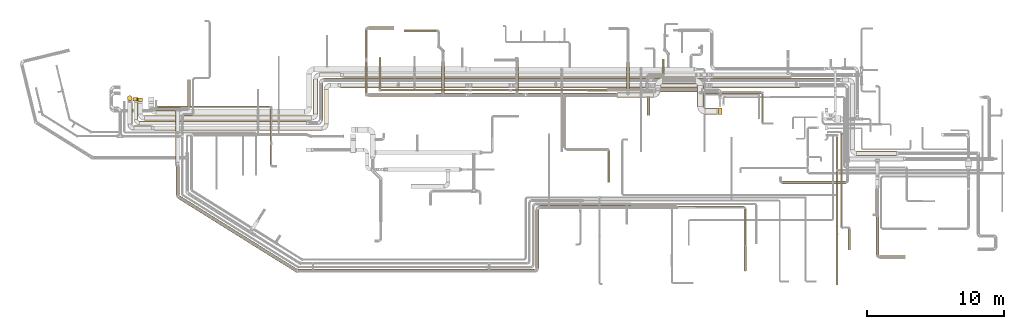
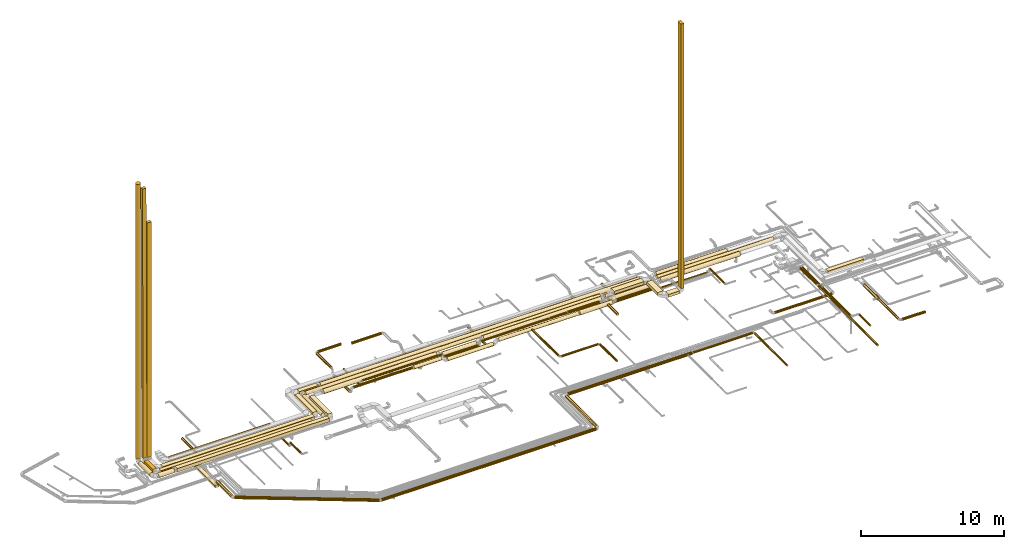
# One storey, part 1 of 92: 76 coverings.
"""IFC2X3 building model written with IfcOpenShell, lengths in millimetres."""

import ifcopenshell
import ifcopenshell.guid

model = None  # the IFC model being written
_history = None  # IfcOwnerHistory: only IFC2X3 demands one
_inside = {}  # id of a spatial element -> (the spatial element, [elements in it])
_under = {}  # id of a project, library or spatial element -> (it, [spatial elements below it])
_declared = {}  # id of a project -> (the project, [libraries it declares])
_typed = {}  # id of a type object -> (the type object, [elements of that type])
_made_of = {}  # id of a material, layer set ... -> (it, [elements and type objects made of it])


def new_model(schema):
    """Start an empty IFC model of exactly this schema.

    Asked for "IFC4X3", IfcOpenShell would pick the latest addendum, in which some entities
    have other attributes; the version numbers below select the first issue.
    IFC2X3 requires an IfcOwnerHistory on every rooted entity: one is made here for all.
    """
    global model, _history
    if schema == "IFC4X3":
        model = ifcopenshell.file(schema_version=(4, 3, 0, 0))
    else:
        model = ifcopenshell.file(schema=schema)
    _inside.clear()
    _under.clear()
    _declared.clear()
    _typed.clear()
    _made_of.clear()
    _history = None
    if model.schema == "IFC2X3":
        org = make("IfcOrganization", Name="unknown")
        user = make(
            "IfcPersonAndOrganization",
            ThePerson=make("IfcPerson", FamilyName="unknown"),
            TheOrganization=org,
        )
        app = make(
            "IfcApplication",
            ApplicationDeveloper=org,
            Version="unknown",
            ApplicationFullName="unknown",
            ApplicationIdentifier="unknown",
        )
        _history = make(
            "IfcOwnerHistory",
            OwningUser=user,
            OwningApplication=app,
            ChangeAction="ADDED",
            CreationDate=0,
        )
    return model


def make(cls, **values):
    """One entity of the class cls with the attributes given. An attribute that is None is left unset."""
    return model.create_entity(
        cls, **{name: value for name, value in values.items() if value is not None}
    )


def entity(cls, *values):
    """Any entity or typed value of the class cls, its attributes in the order of the schema. None: left unset."""
    e = model.create_entity(cls)
    for i, value in enumerate(values):
        if value is not None:
            e[i] = value
    return e


def rooted(cls, **values):
    """An entity with a GlobalId (a new one), such as an element, a storey or a relation."""
    return make(cls, GlobalId=ifcopenshell.guid.new(), OwnerHistory=_history, **values)


def si_unit(unit_type, name, prefix=None):
    """IfcSIUnit, for example si_unit("LENGTHUNIT", "METRE", prefix="MILLI")."""
    return make("IfcSIUnit", UnitType=unit_type, Prefix=prefix, Name=name)


def converted_unit(unit_type, name, factor, base, dimensions=None, offset=None):
    """IfcConversionBasedUnit, such as the inch: factor (a typed value) times the base unit."""
    return make(
        "IfcConversionBasedUnit"
        if offset is None
        else "IfcConversionBasedUnitWithOffset",
        ConversionOffset=offset,
        Dimensions=None
        if dimensions is None
        else entity("IfcDimensionalExponents", *dimensions),
        UnitType=unit_type,
        Name=name,
        ConversionFactor=make(
            "IfcMeasureWithUnit", ValueComponent=factor, UnitComponent=base
        ),
    )


def derived_unit(unit_type, elements):
    """IfcDerivedUnit: a product of units, each with its exponent."""
    return make(
        "IfcDerivedUnit",
        Elements=[
            make("IfcDerivedUnitElement", Unit=unit, Exponent=power)
            for unit, power in elements
        ],
        UnitType=unit_type,
    )


def assignment(units):
    """IfcUnitAssignment: the units of a project."""
    return None if units is None else make("IfcUnitAssignment", Units=units)


def point(xyz):
    """IfcCartesianPoint."""
    return None if xyz is None else make("IfcCartesianPoint", Coordinates=xyz)


def direction(xyz):
    """IfcDirection."""
    return None if xyz is None else make("IfcDirection", DirectionRatios=xyz)


def frame(location, z_axis=None, x_axis=None):
    """IfcAxis2Placement3D, a coordinate frame: its origin and axes. An axis left out is left unset."""
    return make(
        "IfcAxis2Placement3D",
        Location=point(location),
        Axis=direction(z_axis),
        RefDirection=direction(x_axis),
    )


def frame_2d(location, x_axis=None):
    """IfcAxis2Placement2D, a coordinate frame in the plane: its origin and x axis."""
    return make(
        "IfcAxis2Placement2D", Location=point(location), RefDirection=direction(x_axis)
    )


def origin():
    """The frame at (0, 0, 0) with its axes left unset."""
    return frame((0.0, 0.0, 0.0))


def origin_2d_with_axis():
    """The frame at (0, 0) in the plane with the x axis (1, 0) written out."""
    return frame_2d((0.0, 0.0), x_axis=(1.0, 0.0))


def place(relative_to, where):
    """IfcLocalPlacement: puts the frame where relative to a parent placement (None: the world)."""
    return make(
        "IfcLocalPlacement", PlacementRelTo=relative_to, RelativePlacement=where
    )


def context(
    kind, dimensions, precision=None, world=None, true_north=None, identifier=None
):
    """IfcGeometricRepresentationContext, for example the 3D "Model" context."""
    return make(
        "IfcGeometricRepresentationContext",
        ContextIdentifier=identifier,
        ContextType=kind,
        CoordinateSpaceDimension=dimensions,
        Precision=precision,
        WorldCoordinateSystem=world,
        TrueNorth=true_north,
    )


def subcontext(parent, identifier, kind, view, scale=None):
    """IfcGeometricRepresentationSubContext, for example "Body" below "Model"."""
    return make(
        "IfcGeometricRepresentationSubContext",
        ContextIdentifier=identifier,
        ContextType=kind,
        ParentContext=parent,
        TargetScale=scale,
        TargetView=view,
    )


def project(units=None, contexts=None):
    """IfcProject with its units and contexts."""
    return rooted(
        "IfcProject",
        Name="project",
        RepresentationContexts=contexts,
        UnitsInContext=assignment(units),
    )


def spatial(cls, under=None, at=None, **own):
    """A site, building, storey or space (cls), placed at a placement, below another one or the project."""
    s = rooted(cls, ObjectPlacement=at, **own)
    if under is not None:
        _under.setdefault(under.id(), (under, []))[1].append(s)
    return s


def profile(cls, at=None, kind="AREA", **sizes):
    """A parametric profile (cls). Its sizes go by their IFC names, for example OverallWidth=200.0."""
    return make(cls, ProfileType=kind, Position=at, **sizes)


def rectangle(**sizes):
    """IfcRectangleProfileDef."""
    return profile("IfcRectangleProfileDef", **sizes)


def circle(**sizes):
    """IfcCircleProfileDef."""
    return profile("IfcCircleProfileDef", **sizes)


def extrude(swept, where, along, depth):
    """IfcExtrudedAreaSolid: the profile swept, set in the frame where, extruded along a direction by depth."""
    return make(
        "IfcExtrudedAreaSolid",
        SweptArea=swept,
        Position=where,
        ExtrudedDirection=direction(along),
        Depth=depth,
    )


def shape(context_of_items, identifier, shape_type, items):
    """IfcShapeRepresentation: the items that make up one representation, for example the "Body"."""
    return make(
        "IfcShapeRepresentation",
        ContextOfItems=context_of_items,
        RepresentationIdentifier=identifier,
        RepresentationType=shape_type,
        Items=items,
    )


def made_of(thing, what):
    """Note that an element or type object is made of a material, layer set ...; save() writes the relation."""
    if what is not None:
        _made_of.setdefault(what.id(), (what, []))[1].append(thing)
    return thing


def element(
    cls,
    number,
    at=None,
    inside=None,
    cuts=None,
    type_object=None,
    material=None,
    context=None,
    identifier="Body",
    shape_type=None,
    held_by="IfcProductDefinitionShape",
    body=None,
    shapes=None,
    **own,
):
    """One element of the class cls, such as IfcWall. Its Tag is "e" and its number.

    at: its placement. inside: the storey or other place that contains it. cuts: it is an
    opening in that element (IfcRelVoidsElement). A single representation is given by context,
    identifier, shape_type and body (its items); several are given by shapes. held_by: the class
    of the entity that holds the representations. save() writes the other relations.
    """
    e = rooted(cls, Tag="e%d" % number, ObjectPlacement=at, **own)
    if body is not None:
        shapes = [shape(context, identifier, shape_type, body)]
    if shapes is not None:
        e.Representation = make(held_by, Representations=shapes)
    if inside is not None:
        _inside.setdefault(inside.id(), (inside, []))[1].append(e)
    if cuts is not None:
        rooted(
            "IfcRelVoidsElement", RelatingBuildingElement=cuts, RelatedOpeningElement=e
        )
    if type_object is not None:
        _typed.setdefault(type_object.id(), (type_object, []))[1].append(e)
    return made_of(e, material)


def aggregate(whole, parts):
    """IfcRelAggregates: a whole, such as a stair, and the parts it consists of."""
    return rooted("IfcRelAggregates", RelatingObject=whole, RelatedObjects=parts)


def save(model, path):
    """Write the relations noted so far, then the file.

    IfcRelAggregates (storeys below a building ...), IfcRelContainedInSpatialStructure (elements
    in a storey), IfcRelDefinesByType, IfcRelAssociatesMaterial and IfcRelDeclares: one each for
    every whole, place, type object, material and project.
    """
    for whole, parts in _under.values():
        aggregate(whole, parts)
    for where, things in _inside.values():
        rooted(
            "IfcRelContainedInSpatialStructure",
            RelatedElements=things,
            RelatingStructure=where,
        )
    for kind, things in _typed.values():
        rooted("IfcRelDefinesByType", RelatedObjects=things, RelatingType=kind)
    for what, things in _made_of.values():
        rooted("IfcRelAssociatesMaterial", RelatedObjects=things, RelatingMaterial=what)
    for by, libraries in _declared.values():
        rooted("IfcRelDeclares", RelatingContext=by, RelatedDefinitions=libraries)
    model.write(path)


model = new_model("IFC2X3")

# Units and contexts
model_context = context("Model", 3, precision=0.01, world=origin(), true_north=direction((6.12303176911189e-17, 1.0)))
body_context = subcontext(model_context, "Body", "Model", "MODEL_VIEW")
ifc_project = project(units=[si_unit("LENGTHUNIT", "METRE", prefix="MILLI"), si_unit("AREAUNIT", "SQUARE_METRE"), si_unit("VOLUMEUNIT", "CUBIC_METRE"), converted_unit("PLANEANGLEUNIT", "DEGREE", entity("IfcRatioMeasure", 0.0174532925199433), si_unit("PLANEANGLEUNIT", "RADIAN"), dimensions=[0, 0, 0, 0, 0, 0, 0]), si_unit("MASSUNIT", "GRAM", prefix="KILO"), derived_unit("MASSDENSITYUNIT", [(si_unit("MASSUNIT", "GRAM", prefix="KILO"), 1), (si_unit("LENGTHUNIT", "METRE"), -3)]), derived_unit("MOMENTOFINERTIAUNIT", [(si_unit("LENGTHUNIT", "METRE"), 4)]), si_unit("TIMEUNIT", "SECOND"), si_unit("FREQUENCYUNIT", "HERTZ"), si_unit("THERMODYNAMICTEMPERATUREUNIT", "DEGREE_CELSIUS"), derived_unit("THERMALTRANSMITTANCEUNIT", [(si_unit("MASSUNIT", "GRAM", prefix="KILO"), 1), (si_unit("THERMODYNAMICTEMPERATUREUNIT", "KELVIN"), -1), (si_unit("TIMEUNIT", "SECOND"), -3)]), derived_unit("VOLUMETRICFLOWRATEUNIT", [(si_unit("LENGTHUNIT", "METRE"), 3), (si_unit("TIMEUNIT", "SECOND"), -1)]), derived_unit("MASSFLOWRATEUNIT", [(si_unit("MASSUNIT", "GRAM", prefix="KILO"), 1), (si_unit("TIMEUNIT", "SECOND"), -1)]), derived_unit("ROTATIONALFREQUENCYUNIT", [(si_unit("TIMEUNIT", "SECOND"), -1)]), si_unit("ELECTRICCURRENTUNIT", "AMPERE"), si_unit("ELECTRICVOLTAGEUNIT", "VOLT"), si_unit("POWERUNIT", "WATT"), si_unit("FORCEUNIT", "NEWTON", prefix="KILO"), si_unit("ILLUMINANCEUNIT", "LUX"), si_unit("LUMINOUSFLUXUNIT", "LUMEN"), si_unit("LUMINOUSINTENSITYUNIT", "CANDELA"), derived_unit("USERDEFINED", [(si_unit("MASSUNIT", "GRAM", prefix="KILO"), -1), (si_unit("LENGTHUNIT", "METRE"), -2), (si_unit("TIMEUNIT", "SECOND"), 3), (si_unit("LUMINOUSFLUXUNIT", "LUMEN"), 1)]), derived_unit("LINEARVELOCITYUNIT", [(si_unit("LENGTHUNIT", "METRE"), 1), (si_unit("TIMEUNIT", "SECOND"), -1)]), si_unit("PRESSUREUNIT", "PASCAL"), derived_unit("USERDEFINED", [(si_unit("LENGTHUNIT", "METRE"), -2), (si_unit("MASSUNIT", "GRAM", prefix="KILO"), 1), (si_unit("TIMEUNIT", "SECOND"), -2)]), derived_unit("LINEARFORCEUNIT", [(si_unit("MASSUNIT", "GRAM", prefix="KILO"), 1), (si_unit("LENGTHUNIT", "METRE"), 1), (si_unit("TIMEUNIT", "SECOND"), -2), (si_unit("LENGTHUNIT", "METRE"), -1)]), derived_unit("PLANARFORCEUNIT", [(si_unit("MASSUNIT", "GRAM", prefix="KILO"), 1), (si_unit("LENGTHUNIT", "METRE"), 1), (si_unit("TIMEUNIT", "SECOND"), -2), (si_unit("LENGTHUNIT", "METRE"), -2)])], contexts=[model_context])

# Site, building, storey
site_placement = place(None, origin())
site = spatial("IfcSite", under=ifc_project, at=site_placement, CompositionType="ELEMENT")
building_placement = place(site_placement, origin())
building = spatial("IfcBuilding", under=site, at=building_placement, CompositionType="ELEMENT")
storey_placement = place(building_placement, frame((0.0, 0.0, 4200.0)))
storey = spatial("IfcBuildingStorey", under=building, at=storey_placement, CompositionType="ELEMENT", Elevation=4200.0)

# Coverings
covering_1_placement = place(storey_placement, frame((50095.11, 13411.01, 3232.5)))
element("IfcCovering", 1, at=covering_1_placement, inside=storey, PredefinedType="INSULATION", context=body_context, shape_type="SweptSolid", body=[
    extrude(rectangle(XDim=1520.98631635608, YDim=450.000000000002, at=origin_2d_with_axis()), frame((225.0, 760.49, 0.0), z_axis=(0.0, 0.0, 1.0), x_axis=(0.0, 1.0, 0.0)), (0.0, 0.0, 1.0), 249.999999999999),
])
covering_2_placement = place(storey_placement, frame((47570.11, 15057.0, 3232.5)))
element("IfcCovering", 2, at=covering_2_placement, inside=storey, PredefinedType="INSULATION", context=body_context, shape_type="SweptSolid", body=[
    extrude(rectangle(XDim=2400.00000000001, YDim=450.000000000002, at=origin_2d_with_axis()), frame((1200.0, 225.0, 0.0), z_axis=(0.0, 0.0, 1.0), x_axis=(-1.0, 0.0, 0.0)), (0.0, 0.0, 1.0), 249.999999999999),
])
covering_3_placement = place(storey_placement, frame((54784.02, 12264.71, 3223.4)))
element("IfcCovering", 3, at=covering_3_placement, inside=storey, PredefinedType="INSULATION", context=body_context, shape_type="SweptSolid", body=[
    extrude(circle(Radius=75.0, at=origin_2d_with_axis()), frame((76.6, 0.0, 76.6), z_axis=(0.0, 1.0, 0.0), x_axis=(1.0, 0.0, 0.0)), (0.0, 0.0, 1.0), 2045.66723864255),
])
covering_4_placement = place(storey_placement, frame((37727.45, 14090.4, 3148.4)))
element("IfcCovering", 4, at=covering_4_placement, inside=storey, PredefinedType="INSULATION", context=body_context, shape_type="SweptSolid", body=[
    extrude(circle(Radius=150.0, at=origin_2d_with_axis()), frame((0.0, 151.6, 151.6), z_axis=(1.0, 0.0, 0.0), x_axis=(0.0, -1.0, 0.0)), (0.0, 0.0, 1.0), 6470.60249485662),
])
covering_5_placement = place(storey_placement, frame((40329.43, 10417.36, 3210.9)))
element("IfcCovering", 5, at=covering_5_placement, inside=storey, PredefinedType="INSULATION", context=body_context, shape_type="SweptSolid", body=[
    extrude(circle(Radius=87.5, at=origin_2d_with_axis()), frame((89.1, 0.0, 89.1), z_axis=(0.0, 1.0, 0.0), x_axis=(-1.0, 0.0, 0.0)), (0.0, 0.0, 1.0), 3679.63829635603),
])
covering_6_placement = place(storey_placement, frame((40543.53, 10203.27, 3210.9)))
element("IfcCovering", 6, at=covering_6_placement, inside=storey, PredefinedType="INSULATION", context=body_context, shape_type="SweptSolid", body=[
    extrude(circle(Radius=87.5, at=origin_2d_with_axis()), frame((0.0, 89.1, 89.1), z_axis=(1.0, 0.0, 0.0), x_axis=(0.0, 1.0, 0.0)), (0.0, 0.0, 1.0), 2950.00000000008),
])
covering_7_placement = place(storey_placement, frame((43529.43, 7853.98, 3210.9)))
element("IfcCovering", 7, at=covering_7_placement, inside=storey, PredefinedType="INSULATION", context=body_context, shape_type="SweptSolid", body=[
    extrude(circle(Radius=87.5, at=origin_2d_with_axis()), frame((89.1, 0.0, 89.1), z_axis=(0.0, 1.0, 0.0), x_axis=(1.0, 0.0, 0.0)), (0.0, 0.0, 1.0), 2313.38222094977),
])
covering_8_placement = place(storey_placement, frame((28660.55, 18841.88, 3233.4)))
element("IfcCovering", 8, at=covering_8_placement, inside=storey, PredefinedType="INSULATION", context=body_context, shape_type="SweptSolid", body=[
    extrude(circle(Radius=105.0, at=origin_2d_with_axis()), frame((0.0, 106.6, 106.6), z_axis=(1.0, 0.0, 0.0), x_axis=(0.0, -1.0, 0.0)), (0.0, 0.0, 1.0), 2369.44948828407),
])
covering_9_placement = place(storey_placement, frame((26051.62, 14135.4, 3236.1)))
element("IfcCovering", 9, at=covering_9_placement, inside=storey, PredefinedType="INSULATION", context=body_context, shape_type="SweptSolid", body=[
    extrude(circle(Radius=105.0, at=origin_2d_with_axis()), frame((0.0, 106.6, 106.6), z_axis=(1.0, 0.0, 0.0), x_axis=(0.0, 1.0, 0.0)), (0.0, 0.0, 1.0), 4759.98447387883),
])
covering_10_placement = place(storey_placement, frame((25785.03, 14402.0, 2853.4)))
element("IfcCovering", 10, at=covering_10_placement, inside=storey, PredefinedType="INSULATION", context=body_context, shape_type="SweptSolid", body=[
    extrude(circle(Radius=105.0, at=origin_2d_with_axis()), frame((106.6, 0.0, 106.6), z_axis=(0.0, 1.0, 0.0), x_axis=(-1.0, 0.0, 0.0)), (0.0, 0.0, 1.0), 2267.32089470054),
])
covering_11_placement = place(storey_placement, frame((26051.62, 19038.38, 3293.4)))
element("IfcCovering", 11, at=covering_11_placement, inside=storey, PredefinedType="INSULATION", context=body_context, shape_type="SweptSolid", body=[
    extrude(circle(Radius=105.0, at=origin_2d_with_axis()), frame((0.0, 106.6, 106.6), z_axis=(1.0, 0.0, 0.0), x_axis=(0.0, 1.0, 0.0)), (0.0, 0.0, 1.0), 1859.98447387882),
])
covering_12_placement = place(storey_placement, frame((46417.59, 12754.72, 3193.4)))
element("IfcCovering", 12, at=covering_12_placement, inside=storey, PredefinedType="INSULATION", context=body_context, shape_type="SweptSolid", body=[
    extrude(circle(Radius=105.0, at=origin_2d_with_axis()), frame((106.6, 0.0, 106.6), z_axis=(0.0, 1.0, 0.0), x_axis=(1.0, 0.0, 0.0)), (0.0, 0.0, 1.0), 1309.78330185936),
])
covering_13_placement = place(storey_placement, frame((50420.11, 14333.78, 2923.4)))
element("IfcCovering", 13, at=covering_13_placement, inside=storey, PredefinedType="INSULATION", context=body_context, shape_type="SweptSolid", body=[
    extrude(circle(Radius=75.0, at=origin_2d_with_axis()), frame((0.0, 76.6, 76.6), z_axis=(1.0, 0.0, 0.0), x_axis=(0.0, -1.0, 0.0)), (0.0, 0.0, 1.0), 4340.50941430596),
])
covering_14_placement = place(storey_placement, frame((36796.88, 14581.05, 2913.4)))
element("IfcCovering", 14, at=covering_14_placement, inside=storey, PredefinedType="INSULATION", context=body_context, shape_type="SweptSolid", body=[
    extrude(circle(Radius=105.0, at=origin_2d_with_axis()), frame((106.6, 0.0, 106.6), z_axis=(0.0, 1.0, 0.0), x_axis=(1.0, 0.0, 0.0)), (0.0, 0.0, 1.0), 2362.80180988255),
])
covering_15_placement = place(storey_placement, frame((33609.15, 14090.4, 2938.4)))
element("IfcCovering", 15, at=covering_15_placement, inside=storey, PredefinedType="INSULATION", context=body_context, shape_type="SweptSolid", body=[
    extrude(circle(Radius=150.0, at=origin_2d_with_axis()), frame((0.0, 151.6, 151.6), z_axis=(1.0, 0.0, 0.0), x_axis=(0.0, -1.0, 0.0)), (0.0, 0.0, 1.0), 3701.1902490397),
])
covering_16_placement = place(storey_placement, frame((30901.61, 14090.4, 3191.1)))
element("IfcCovering", 16, at=covering_16_placement, inside=storey, PredefinedType="INSULATION", context=body_context, shape_type="SweptSolid", body=[
    extrude(circle(Radius=150.0, at=origin_2d_with_axis()), frame((0.0, 151.6, 151.6), z_axis=(1.0, 0.0, 0.0), x_axis=(0.0, 1.0, 0.0)), (0.0, 0.0, 1.0), 2247.74030313738),
])
covering_17_placement = place(storey_placement, frame((44263.05, 14057.9, 3115.9)))
element("IfcCovering", 17, at=covering_17_placement, inside=storey, PredefinedType="INSULATION", context=body_context, shape_type="SweptSolid", body=[
    extrude(circle(Radius=182.5, at=origin_2d_with_axis()), frame((0.0, 184.1, 184.1), z_axis=(1.0, 0.0, 0.0), x_axis=(0.0, 1.0, 0.0)), (0.0, 0.0, 1.0), 2642.05640556863),
])
covering_18_placement = place(storey_placement, frame((50670.11, 12836.01, 3232.5)))
element("IfcCovering", 18, at=covering_18_placement, inside=storey, PredefinedType="INSULATION", context=body_context, shape_type="SweptSolid", body=[
    extrude(rectangle(XDim=871.252251145747, YDim=450.000000000002, at=origin_2d_with_axis()), frame((435.63, 225.0, 0.0)), (0.0, 0.0, 1.0), 249.999999999999),
])
covering_19_placement = place(storey_placement, frame((25785.03, 16989.32, 3293.4)))
element("IfcCovering", 19, at=covering_19_placement, inside=storey, PredefinedType="INSULATION", context=body_context, shape_type="SweptSolid", body=[
    extrude(circle(Radius=105.0, at=origin_2d_with_axis()), frame((106.6, 0.0, 106.6), z_axis=(0.0, 1.0, 0.0), x_axis=(1.0, 0.0, 0.0)), (0.0, 0.0, 1.0), 1995.65663894343),
])
covering_20_placement = place(storey_placement, frame((12130.46, 1302.76, 3223.4)))
element("IfcCovering", 20, at=covering_20_placement, inside=storey, PredefinedType="INSULATION", context=body_context, shape_type="SweptSolid", body=[
    extrude(circle(Radius=125.0, at=origin_2d_with_axis()), frame((67.83, 5475.08, 126.6), z_axis=(0.848052743777567, -0.529911826412037, 0.0), x_axis=(0.529911826412037, 0.848052743777567, 0.0)), (0.0, 0.0, 1.0), 10129.0097516461),
])
covering_21_placement = place(storey_placement, frame((20894.21, 1253.38, 3223.4)))
element("IfcCovering", 21, at=covering_21_placement, inside=storey, PredefinedType="INSULATION", context=body_context, shape_type="SweptSolid", body=[
    extrude(circle(Radius=125.0, at=origin_2d_with_axis()), frame((0.0, 126.6, 126.6), z_axis=(1.0, 0.0, 0.0), x_axis=(0.0, 1.0, 0.0)), (0.0, 0.0, 1.0), 17295.5336074922),
])
covering_22_placement = place(storey_placement, frame((38263.15, 1579.97, 3223.4)))
element("IfcCovering", 22, at=covering_22_placement, inside=storey, PredefinedType="INSULATION", context=body_context, shape_type="SweptSolid", body=[
    extrude(circle(Radius=125.000000000003, at=origin_2d_with_axis()), frame((126.6, 0.0, 126.6), z_axis=(0.0, 1.0, -3.30738458842461e-09), x_axis=(-1.0, 0.0, 0.0)), (0.0, 0.0, 1.0), 4244.85231843357),
])
covering_23_placement = place(storey_placement, frame((38589.74, 5897.98, 3223.4)))
element("IfcCovering", 23, at=covering_23_placement, inside=storey, PredefinedType="INSULATION", context=body_context, shape_type="SweptSolid", body=[
    extrude(circle(Radius=125.0, at=origin_2d_with_axis()), frame((0.0, 126.6, 126.6), z_axis=(1.0, 0.0, 0.0), x_axis=(0.0, 1.0, 0.0)), (0.0, 0.0, 1.0), 10000.0),
])
covering_24_placement = place(storey_placement, frame((48664.74, 5935.48, 3260.9)))
element("IfcCovering", 24, at=covering_24_placement, inside=storey, PredefinedType="INSULATION", context=body_context, shape_type="SweptSolid", body=[
    extrude(circle(Radius=87.5, at=origin_2d_with_axis()), frame((0.0, 89.1, 89.1), z_axis=(1.0, 0.0, 0.0), x_axis=(0.0, -1.0, 0.0)), (0.0, 0.0, 1.0), 4816.79215817312),
])
covering_25_placement = place(storey_placement, frame((53517.44, 3240.11, 3260.9)))
element("IfcCovering", 25, at=covering_25_placement, inside=storey, PredefinedType="INSULATION", context=body_context, shape_type="SweptSolid", body=[
    extrude(circle(Radius=87.5, at=origin_2d_with_axis()), frame((89.1, 0.0, 89.1), z_axis=(0.0, 1.0, 0.0), x_axis=(1.0, 0.0, 0.0)), (0.0, 0.0, 1.0), 2659.465339106),
])
covering_26_placement = place(storey_placement, frame((53529.91, 1369.83, 3273.4)))
element("IfcCovering", 26, at=covering_26_placement, inside=storey, PredefinedType="INSULATION", context=body_context, shape_type="SweptSolid", body=[
    extrude(circle(Radius=75.0, at=origin_2d_with_axis()), frame((76.6, 0.0, 76.6), z_axis=(1.46979839557757e-05, 1.0, 0.0), x_axis=(1.0, -1.46979839557757e-05, 0.0)), (0.0, 0.0, 1.0), 1845.2883705389),
])
covering_27_placement = place(storey_placement, frame((22419.38, 12444.64, 3148.4)))
element("IfcCovering", 27, at=covering_27_placement, inside=storey, PredefinedType="INSULATION", context=body_context, shape_type="SweptSolid", body=[
    extrude(circle(Radius=150.0, at=origin_2d_with_axis()), frame((151.6, 0.0, 151.6), z_axis=(0.0, 1.0, 0.0), x_axis=(-1.0, 0.0, 0.0)), (0.0, 0.0, 1.0), 2644.85632414976),
])
covering_28_placement = place(storey_placement, frame((61744.33, 9799.93, 3175.0)))
element("IfcCovering", 28, at=covering_28_placement, inside=storey, PredefinedType="INSULATION", context=body_context, shape_type="SweptSolid", body=[
    extrude(rectangle(XDim=2915.97201907617, YDim=349.999999999998, at=origin_2d_with_axis()), frame((1457.99, 175.0, 0.0), z_axis=(0.0, 0.0, 1.0), x_axis=(-1.0, 0.0, 0.0)), (0.0, 0.0, 1.0), 249.999999999999),
])
covering_29_placement = place(storey_placement, frame((9324.12, 12044.64, 3175.0)))
element("IfcCovering", 29, at=covering_29_placement, inside=storey, PredefinedType="INSULATION", context=body_context, shape_type="SweptSolid", body=[
    extrude(rectangle(XDim=12199.9289354935, YDim=300.000000000001, at=origin_2d_with_axis()), frame((6099.96, 150.0, 0.0)), (0.0, 0.0, 1.0), 249.999999999999),
])
covering_30_placement = place(storey_placement, frame((51118.94, 15187.9, 3123.4)))
element("IfcCovering", 30, at=covering_30_placement, inside=storey, PredefinedType="INSULATION", context=body_context, shape_type="SweptSolid", body=[
    extrude(circle(Radius=150.0, at=origin_2d_with_axis()), frame((0.0, 151.6, 151.6), z_axis=(1.0, 0.0, 0.0), x_axis=(0.0, -1.0, 0.0)), (0.0, 0.0, 1.0), 9385.38873552541),
])
covering_31_placement = place(storey_placement, frame((8899.12, 12469.64, 3175.0)))
element("IfcCovering", 31, at=covering_31_placement, inside=storey, PredefinedType="INSULATION", context=body_context, shape_type="SweptSolid", body=[
    extrude(rectangle(XDim=1214.24739279422, YDim=299.999999999999, at=origin_2d_with_axis()), frame((150.0, 607.12, 0.0), z_axis=(0.0, 0.0, 1.0), x_axis=(0.0, 1.0, 0.0)), (0.0, 0.0, 1.0), 249.999999999999),
])
covering_32_placement = place(storey_placement, frame((8837.99, 13808.89, 3549.6)))
element("IfcCovering", 32, at=covering_32_placement, inside=storey, PredefinedType="INSULATION", context=body_context, shape_type="SweptSolid", body=[
    extrude(rectangle(XDim=300.0, YDim=249.999999999999, at=frame_2d((0.0, 0.0), x_axis=(0.0, 1.0))), frame((210.48, 125.0, 0.4), z_axis=(-0.00263533361907096, 0.0, 0.999996527502329), x_axis=(0.0, 1.0, 0.0)), (0.0, 0.0, 1.0), 22950.0814303531),
])
covering_33_placement = place(storey_placement, frame((46962.18, 15187.9, 2938.4)))
element("IfcCovering", 33, at=covering_33_placement, inside=storey, PredefinedType="INSULATION", context=body_context, shape_type="SweptSolid", body=[
    extrude(circle(Radius=150.0, at=origin_2d_with_axis()), frame((0.0, 151.6, 151.6), z_axis=(1.0, 0.0, 0.0), x_axis=(0.0, 1.0, 0.0)), (0.0, 0.0, 1.0), 3764.65963583973),
])
covering_34_placement = place(storey_placement, frame((43531.01, 14492.9, 3252.89)))
element("IfcCovering", 34, at=covering_34_placement, inside=storey, PredefinedType="INSULATION", context=body_context, shape_type="SweptSolid", body=[
    extrude(circle(Radius=105.0, at=origin_2d_with_axis()), frame((0.0, 106.6, 106.6), z_axis=(1.0, 0.0, 0.0), x_axis=(0.0, -1.0, 0.0)), (0.0, 0.0, 1.0), 2569.99999999998),
])
covering_35_placement = place(storey_placement, frame((42091.01, 14510.4, 3270.39)))
element("IfcCovering", 35, at=covering_35_placement, inside=storey, PredefinedType="INSULATION", context=body_context, shape_type="SweptSolid", body=[
    extrude(circle(Radius=87.5, at=origin_2d_with_axis()), frame((0.0, 89.1, 89.1), z_axis=(1.0, 0.0, 0.0), x_axis=(0.0, -1.0, 0.0)), (0.0, 0.0, 1.0), 1405.0),
])
covering_36_placement = place(storey_placement, frame((36545.15, 14522.9, 3282.89)))
element("IfcCovering", 36, at=covering_36_placement, inside=storey, PredefinedType="INSULATION", context=body_context, shape_type="SweptSolid", body=[
    extrude(circle(Radius=75.0, at=origin_2d_with_axis()), frame((0.0, 76.6, 76.6), z_axis=(1.0, 0.0, 0.0), x_axis=(0.0, -1.0, 0.0)), (0.0, 0.0, 1.0), 5520.85892677341),
])
covering_37_placement = place(storey_placement, frame((26809.47, 14699.5, 2873.4)))
element("IfcCovering", 37, at=covering_37_placement, inside=storey, PredefinedType="INSULATION", context=body_context, shape_type="SweptSolid", body=[
    extrude(circle(Radius=75.0, at=origin_2d_with_axis()), frame((76.6, 0.0, 76.6), z_axis=(0.0, 1.0, 0.0), x_axis=(-1.0, 0.0, 0.0)), (0.0, 0.0, 1.0), 2300.00000000001),
])
covering_38_placement = place(storey_placement, frame((47063.58, 14472.9, 2873.4)))
element("IfcCovering", 38, at=covering_38_placement, inside=storey, PredefinedType="INSULATION", context=body_context, shape_type="SweptSolid", body=[
    extrude(circle(Radius=125.0, at=origin_2d_with_axis()), frame((0.0, 126.6, 126.6), z_axis=(1.0, 0.0, 0.0), x_axis=(0.0, -1.0, 0.0)), (0.0, 0.0, 1.0), 3352.50350688958),
])
covering_39_placement = place(storey_placement, frame((26986.06, 14522.9, 3273.4)))
element("IfcCovering", 39, at=covering_39_placement, inside=storey, PredefinedType="INSULATION", context=body_context, shape_type="SweptSolid", body=[
    extrude(circle(Radius=75.0, at=origin_2d_with_axis()), frame((0.0, 76.6, 76.6), z_axis=(1.0, 0.0, 0.0), x_axis=(0.0, 1.0, 0.0)), (0.0, 0.0, 1.0), 6397.81081855833),
])
covering_40_placement = place(storey_placement, frame((33583.87, 14522.9, 3013.4)))
element("IfcCovering", 40, at=covering_40_placement, inside=storey, PredefinedType="INSULATION", context=body_context, shape_type="SweptSolid", body=[
    extrude(circle(Radius=75.0, at=origin_2d_with_axis()), frame((0.0, 76.6, 76.6), z_axis=(1.0, 0.0, 0.0), x_axis=(0.0, 1.0, 0.0)), (0.0, 0.0, 1.0), 2761.28136761189),
])
covering_41_placement = place(storey_placement, frame((18865.46, 9138.08, 3223.4)))
element("IfcCovering", 41, at=covering_41_placement, inside=storey, PredefinedType="INSULATION", context=body_context, shape_type="SweptSolid", body=[
    extrude(circle(Radius=75.0, at=origin_2d_with_axis()), frame((76.6, 0.0, 76.6), z_axis=(0.0, 1.0, 0.0), x_axis=(-1.0, 0.0, 0.0)), (0.0, 0.0, 1.0), 1487.36657000001),
])
covering_42_placement = place(storey_placement, frame((18865.46, 10825.45, 2873.4)))
element("IfcCovering", 42, at=covering_42_placement, inside=storey, PredefinedType="INSULATION", context=body_context, shape_type="SweptSolid", body=[
    extrude(circle(Radius=75.0, at=origin_2d_with_axis()), frame((76.6, 0.0, 76.6), z_axis=(0.0, 1.0, 0.0), x_axis=(-1.0, 0.0, 0.0)), (0.0, 0.0, 1.0), 2428.82870077379),
])
covering_43_placement = place(storey_placement, frame((10624.9, 13277.68, 3223.4)))
element("IfcCovering", 43, at=covering_43_placement, inside=storey, PredefinedType="INSULATION", context=body_context, shape_type="SweptSolid", body=[
    extrude(circle(Radius=75.0, at=origin_2d_with_axis()), frame((0.0, 76.6, 76.6), z_axis=(1.0, 0.0, 0.0), x_axis=(0.0, -1.0, 0.0)), (0.0, 0.0, 1.0), 8217.15723586536),
])
covering_44_placement = place(storey_placement, frame((24215.14, 15537.91, 3115.9)))
element("IfcCovering", 44, at=covering_44_placement, inside=storey, PredefinedType="INSULATION", context=body_context, shape_type="SweptSolid", body=[
    extrude(circle(Radius=182.5, at=origin_2d_with_axis()), frame((0.0, 184.1, 184.1), z_axis=(1.0, 0.0, 0.0), x_axis=(0.0, 1.0, 0.0)), (0.0, 0.0, 1.0), 25749.0296772828),
])
covering_45_placement = place(storey_placement, frame((51265.05, 15537.91, 3065.9)))
element("IfcCovering", 45, at=covering_45_placement, inside=storey, PredefinedType="INSULATION", context=body_context, shape_type="SweptSolid", body=[
    extrude(circle(Radius=182.5, at=origin_2d_with_axis()), frame((0.0, 184.1, 184.1), z_axis=(1.0, 0.0, 0.0), x_axis=(0.0, -1.0, 0.0)), (0.0, 0.0, 1.0), 5715.59598196807),
])
covering_46_placement = place(storey_placement, frame((22017.16, 12869.66, 3175.0)))
element("IfcCovering", 46, at=covering_46_placement, inside=storey, PredefinedType="INSULATION", context=body_context, shape_type="SweptSolid", body=[
    extrude(rectangle(XDim=2552.34371029157, YDim=349.999999999998, at=origin_2d_with_axis()), frame((175.0, 1276.17, 0.0), z_axis=(0.0, 0.0, 1.0), x_axis=(0.0, 1.0, 0.0)), (0.0, 0.0, 1.0), 249.999999999999),
])
covering_47_placement = place(storey_placement, frame((22492.16, 15547.0, 3175.0)))
element("IfcCovering", 47, at=covering_47_placement, inside=storey, PredefinedType="INSULATION", context=body_context, shape_type="SweptSolid", body=[
    extrude(rectangle(XDim=1522.98135691757, YDim=349.999999999998, at=origin_2d_with_axis()), frame((761.49, 175.0, 0.0)), (0.0, 0.0, 1.0), 249.999999999999),
])
covering_48_placement = place(storey_placement, frame((9664.47, 12394.66, 3175.0)))
element("IfcCovering", 48, at=covering_48_placement, inside=storey, PredefinedType="INSULATION", context=body_context, shape_type="SweptSolid", body=[
    extrude(rectangle(XDim=12227.691663082, YDim=349.999999999998, at=origin_2d_with_axis()), frame((6113.85, 175.0, 0.0)), (0.0, 0.0, 1.0), 249.999999999999),
])
covering_49_placement = place(storey_placement, frame((9189.47, 13759.03, 3550.0)))
element("IfcCovering", 49, at=covering_49_placement, inside=storey, PredefinedType="INSULATION", context=body_context, shape_type="SweptSolid", body=[
    extrude(rectangle(XDim=249.999999999999, YDim=350.000000000001, at=origin_2d_with_axis()), frame((175.0, 125.0, 0.0), z_axis=(0.0, 0.0, 1.0), x_axis=(0.0, 1.0, 0.0)), (0.0, 0.0, 1.0), 19965.0),
])
covering_50_placement = place(storey_placement, frame((63144.76, 5381.43, 3073.4)))
element("IfcCovering", 50, at=covering_50_placement, inside=storey, PredefinedType="INSULATION", context=body_context, shape_type="SweptSolid", body=[
    extrude(circle(Radius=125.0, at=origin_2d_with_axis()), frame((126.6, 0.0, 126.6), z_axis=(0.0, 1.0, 0.0), x_axis=(1.0, 0.0, 0.0)), (0.0, 0.0, 1.0), 2000.0),
])
covering_51_placement = place(storey_placement, frame((63164.76, 2558.91, 3113.4)))
element("IfcCovering", 51, at=covering_51_placement, inside=storey, PredefinedType="INSULATION", context=body_context, shape_type="SweptSolid", body=[
    extrude(circle(Radius=105.0, at=origin_2d_with_axis()), frame((106.6, 0.0, 106.6), z_axis=(0.0, 1.0, 0.0), x_axis=(-1.0, 0.0, 0.0)), (0.0, 0.0, 1.0), 2782.5164097574),
])
covering_52_placement = place(storey_placement, frame((63431.35, 2292.31, 3113.4)))
element("IfcCovering", 52, at=covering_52_placement, inside=storey, PredefinedType="INSULATION", context=body_context, shape_type="SweptSolid", body=[
    extrude(circle(Radius=105.0, at=origin_2d_with_axis()), frame((0.0, 106.6, 106.6), z_axis=(1.0, 0.0, 0.0), x_axis=(0.0, 1.0, 0.0)), (0.0, 0.0, 1.0), 1889.99999999994),
])
covering_53_placement = place(storey_placement, frame((8417.31, 12134.68, 3108.4)))
element("IfcCovering", 53, at=covering_53_placement, inside=storey, PredefinedType="INSULATION", context=body_context, shape_type="SweptSolid", body=[
    extrude(circle(Radius=182.5, at=origin_2d_with_axis()), frame((184.1, 0.0, 184.1), z_axis=(0.0, 1.0, 0.0), x_axis=(-1.0, 0.0, 0.0)), (0.0, 0.0, 1.0), 1567.03368000002),
])
covering_54_placement = place(storey_placement, frame((8916.41, 11635.59, 3108.4)))
element("IfcCovering", 54, at=covering_54_placement, inside=storey, PredefinedType="INSULATION", context=body_context, shape_type="SweptSolid", body=[
    extrude(circle(Radius=182.5, at=origin_2d_with_axis()), frame((0.0, 184.1, 184.1), z_axis=(1.0, 0.0, 0.0), x_axis=(0.0, 1.0, 0.0)), (0.0, 0.0, 1.0), 1266.94760898472),
])
covering_55_placement = place(storey_placement, frame((10383.35, 11644.68, 3175.0)))
element("IfcCovering", 55, at=covering_55_placement, inside=storey, PredefinedType="INSULATION", context=body_context, shape_type="SweptSolid", body=[
    extrude(rectangle(XDim=12281.7247260222, YDim=349.999999999998, at=origin_2d_with_axis()), frame((6140.86, 175.0, 0.0), z_axis=(0.0, 0.0, 1.0), x_axis=(-1.0, 0.0, 0.0)), (0.0, 0.0, 1.0), 300.000000000001),
])
covering_56_placement = place(storey_placement, frame((22790.08, 12119.68, 3175.0)))
element("IfcCovering", 56, at=covering_56_placement, inside=storey, PredefinedType="INSULATION", context=body_context, shape_type="SweptSolid", body=[
    extrude(rectangle(XDim=2537.31427635606, YDim=349.999999999998, at=origin_2d_with_axis()), frame((175.0, 1268.66, 0.0), z_axis=(0.0, 0.0, 1.0), x_axis=(0.0, 1.0, 0.0)), (0.0, 0.0, 1.0), 300.000000000001),
])
covering_57_placement = place(storey_placement, frame((36908.04, 14772.9, 3115.9)))
element("IfcCovering", 57, at=covering_57_placement, inside=storey, PredefinedType="INSULATION", context=body_context, shape_type="SweptSolid", body=[
    extrude(circle(Radius=182.5, at=origin_2d_with_axis()), frame((0.0, 184.1, 184.1), z_axis=(1.0, 0.0, 0.0), x_axis=(0.0, -1.0, 0.0)), (0.0, 0.0, 1.0), 9507.22972697121),
])
covering_58_placement = place(storey_placement, frame((56342.62, 7753.26, 2863.4)))
element("IfcCovering", 58, at=covering_58_placement, inside=storey, PredefinedType="INSULATION", context=body_context, shape_type="SweptSolid", body=[
    extrude(circle(Radius=105.0, at=origin_2d_with_axis()), frame((0.0, 106.6, 106.6), z_axis=(1.0, 0.0, 0.0), x_axis=(0.0, 1.0, 0.0)), (0.0, 0.0, 1.0), 4582.38402855465),
])
covering_59_placement = place(storey_placement, frame((24019.73, 14772.9, 3063.4)))
element("IfcCovering", 59, at=covering_59_placement, inside=storey, PredefinedType="INSULATION", context=body_context, shape_type="SweptSolid", body=[
    extrude(circle(Radius=182.5, at=origin_2d_with_axis()), frame((0.0, 184.1, 184.1), z_axis=(1.0, 0.0, 0.0), x_axis=(0.0, 1.0, 0.0)), (0.0, 0.0, 1.0), 9132.10965782929),
])
covering_60_placement = place(storey_placement, frame((33628.08, 14772.9, 2885.9)))
element("IfcCovering", 60, at=covering_60_placement, inside=storey, PredefinedType="INSULATION", context=body_context, shape_type="SweptSolid", body=[
    extrude(circle(Radius=182.5, at=origin_2d_with_axis()), frame((0.0, 184.1, 184.1), z_axis=(1.0, 0.0, 0.0), x_axis=(0.0, -1.0, 0.0)), (0.0, 0.0, 1.0), 2712.77397028846),
])
covering_61_placement = place(storey_placement, frame((51176.63, 14772.9, 3065.9)))
element("IfcCovering", 61, at=covering_61_placement, inside=storey, PredefinedType="INSULATION", context=body_context, shape_type="SweptSolid", body=[
    extrude(circle(Radius=182.5, at=origin_2d_with_axis()), frame((0.0, 184.1, 184.1), z_axis=(1.0, 0.0, 0.0), x_axis=(0.0, -1.0, 0.0)), (0.0, 0.0, 1.0), 6399.99283096227),
])
covering_62_placement = place(storey_placement, frame((47017.09, 14772.9, 2865.9)))
element("IfcCovering", 62, at=covering_62_placement, inside=storey, PredefinedType="INSULATION", context=body_context, shape_type="SweptSolid", body=[
    extrude(circle(Radius=182.5, at=origin_2d_with_axis()), frame((0.0, 184.1, 184.1), z_axis=(1.0, 0.0, 0.0), x_axis=(0.0, 1.0, 0.0)), (0.0, 0.0, 1.0), 3644.32296058967),
])
covering_63_placement = place(storey_placement, frame((11954.27, 9071.64, 2840.0)))
element("IfcCovering", 63, at=covering_63_placement, inside=storey, PredefinedType="INSULATION", context=body_context, shape_type="SweptSolid", body=[
    extrude(rectangle(XDim=4008.35652193022, YDim=300.000000000001, at=origin_2d_with_axis()), frame((150.0, 2004.18, 0.0), z_axis=(0.0, 0.0, 1.0), x_axis=(0.0, -1.0, 0.0)), (0.0, 0.0, 1.0), 200.0),
])
covering_64_placement = place(storey_placement, frame((12828.53, 13380.0, 2793.4)))
element("IfcCovering", 64, at=covering_64_placement, inside=storey, PredefinedType="INSULATION", context=body_context, shape_type="SweptSolid", body=[
    extrude(circle(Radius=105.0, at=origin_2d_with_axis()), frame((106.6, 0.0, 106.6), z_axis=(0.0, 1.0, 0.0), x_axis=(-1.0, 0.0, 0.0)), (0.0, 0.0, 1.0), 1990.99106011782),
])
covering_65_placement = place(storey_placement, frame((10424.44, 13068.4, 2748.4)))
element("IfcCovering", 65, at=covering_65_placement, inside=storey, PredefinedType="INSULATION", context=body_context, shape_type="SweptSolid", body=[
    extrude(circle(Radius=150.0, at=origin_2d_with_axis()), frame((0.0, 151.6, 151.6), z_axis=(1.0, 0.0, 0.0), x_axis=(0.0, -1.0, 0.0)), (0.0, 0.0, 1.0), 1899.83330141568),
])
covering_66_placement = place(storey_placement, frame((11977.68, 6947.46, 3223.4)))
element("IfcCovering", 66, at=covering_66_placement, inside=storey, PredefinedType="INSULATION", context=body_context, shape_type="SweptSolid", body=[
    extrude(circle(Radius=125.0, at=origin_2d_with_axis()), frame((126.6, 0.0, 126.6), z_axis=(0.0, 1.0, 0.0), x_axis=(-1.0, 0.0, 0.0)), (0.0, 0.0, 1.0), 2075.03853452809),
])
covering_67_placement = place(storey_placement, frame((44935.71, 14606.48, 2893.4)))
element("IfcCovering", 67, at=covering_67_placement, inside=storey, PredefinedType="INSULATION", context=body_context, shape_type="SweptSolid", body=[
    extrude(circle(Radius=105.0, at=origin_2d_with_axis()), frame((106.6, 0.0, 106.6), z_axis=(0.0, 1.0, 0.0), x_axis=(-1.0, 0.0, 0.0)), (0.0, 0.0, 1.0), 2056.75272193472),
])
covering_68_placement = place(storey_placement, frame((47503.4, 15821.98, 2893.4)))
element("IfcCovering", 68, at=covering_68_placement, inside=storey, PredefinedType="INSULATION", context=body_context, shape_type="SweptSolid", body=[
    extrude(circle(Radius=105.0, at=origin_2d_with_axis()), frame((106.6, 0.0, 106.6), z_axis=(0.0, 1.0, 0.0), x_axis=(-1.0, 0.0, 0.0)), (0.0, 0.0, 1.0), 1069.53796275342),
])
covering_69_placement = place(storey_placement, frame((60229.86, 8842.68, 3260.9)))
element("IfcCovering", 69, at=covering_69_placement, inside=storey, PredefinedType="INSULATION", context=body_context, shape_type="SweptSolid", body=[
    extrude(circle(Radius=87.5, at=origin_2d_with_axis()), frame((89.1, 0.0, 89.1), z_axis=(0.0, 1.0, 0.0), x_axis=(1.0, 0.0, 0.0)), (0.0, 0.0, 1.0), 2336.4980100004),
])
covering_70_placement = place(storey_placement, frame((60229.86, 354.78, 3260.9)))
element("IfcCovering", 70, at=covering_70_placement, inside=storey, PredefinedType="INSULATION", context=body_context, shape_type="SweptSolid", body=[
    extrude(circle(Radius=87.5, at=origin_2d_with_axis()), frame((89.1, 0.0, 89.1), z_axis=(0.0, 1.0, 0.0), x_axis=(1.0, 0.0, 0.0)), (0.0, 0.0, 1.0), 8287.90000000001),
])
covering_71_placement = place(storey_placement, frame((60560.54, 4655.49, 3073.4)))
element("IfcCovering", 71, at=covering_71_placement, inside=storey, PredefinedType="INSULATION", context=body_context, shape_type="SweptSolid", body=[
    extrude(circle(Radius=75.0, at=origin_2d_with_axis()), frame((76.6, 0.0, 76.6), z_axis=(0.0, 1.0, 0.0), x_axis=(1.0, 0.0, 0.0)), (0.0, 0.0, 1.0), 6769.40199285959),
])
covering_72_placement = place(storey_placement, frame((61134.38, 2924.89, 3073.4)))
element("IfcCovering", 72, at=covering_72_placement, inside=storey, PredefinedType="INSULATION", context=body_context, shape_type="SweptSolid", body=[
    extrude(circle(Radius=75.0, at=origin_2d_with_axis()), frame((76.6, 0.0, 76.6), z_axis=(0.0, 1.0, 0.0), x_axis=(1.0, 0.0, 0.0)), (0.0, 0.0, 1.0), 1530.59800714042),
])
covering_73_placement = place(storey_placement, frame((8417.31, 13832.62, 3607.5)))
element("IfcCovering", 73, at=covering_73_placement, inside=storey, PredefinedType="INSULATION", context=body_context, shape_type="SweptSolid", body=[
    extrude(circle(Radius=182.5, at=origin_2d_with_axis()), frame((184.1, 184.1, 0.0), z_axis=(0.0, 0.0, 1.0), x_axis=(-1.0, 0.0, 0.0)), (0.0, 0.0, 1.0), 23377.5),
])
covering_74_placement = place(storey_placement, frame((51666.36, 12836.01, 3607.5)))
element("IfcCovering", 74, at=covering_74_placement, inside=storey, PredefinedType="INSULATION", context=body_context, shape_type="SweptSolid", body=[
    extrude(rectangle(XDim=249.999999999995, YDim=450.000000000002, at=origin_2d_with_axis()), frame((125.0, 225.0, 0.0), z_axis=(0.0, 0.0, 1.0), x_axis=(-1.0, 0.0, 0.0)), (0.0, 0.0, 1.0), 22542.5000250004),
])
covering_75_placement = place(storey_placement, frame((22820.98, 15187.9, 3148.4)))
element("IfcCovering", 75, at=covering_75_placement, inside=storey, PredefinedType="INSULATION", context=body_context, shape_type="SweptSolid", body=[
    extrude(circle(Radius=150.0, at=origin_2d_with_axis()), frame((0.0, 151.6, 151.6), z_axis=(1.0, 0.0, 0.0), x_axis=(0.0, 1.0, 0.0)), (0.0, 0.0, 1.0), 23724.09576907),
])
covering_76_placement = place(storey_placement, frame((31408.4, 14402.0, 2883.4)))
element("IfcCovering", 76, at=covering_76_placement, inside=storey, PredefinedType="INSULATION", context=body_context, shape_type="SweptSolid", body=[
    extrude(circle(Radius=105.0, at=origin_2d_with_axis()), frame((106.6, 0.0, 106.6), z_axis=(0.0, 1.0, 0.0), x_axis=(1.0, 0.0, 0.0)), (0.0, 0.0, 1.0), 2308.20336366427),
])

save(model, "model.ifc")
